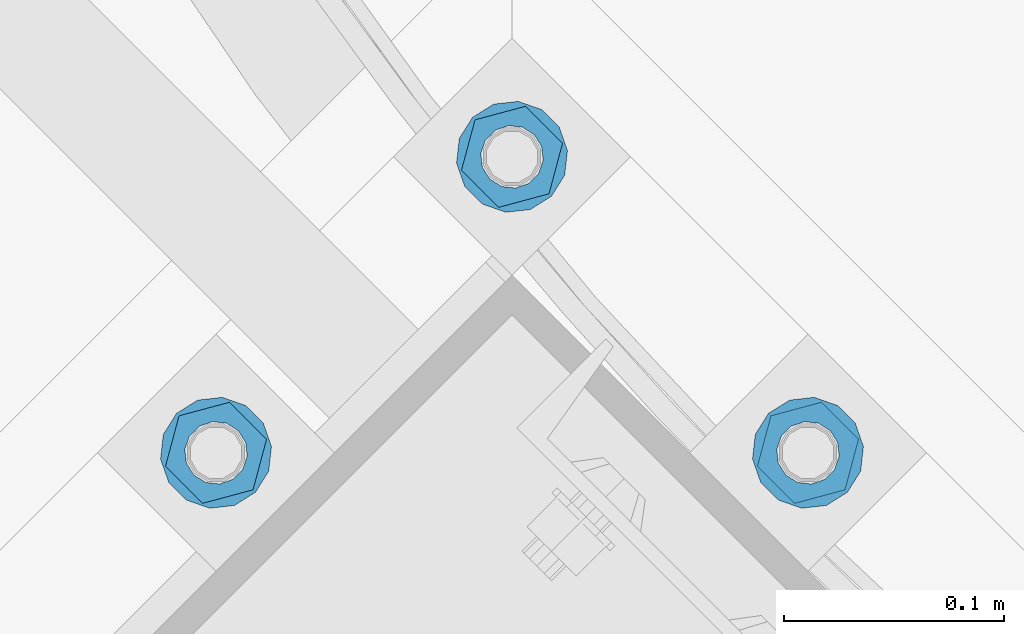
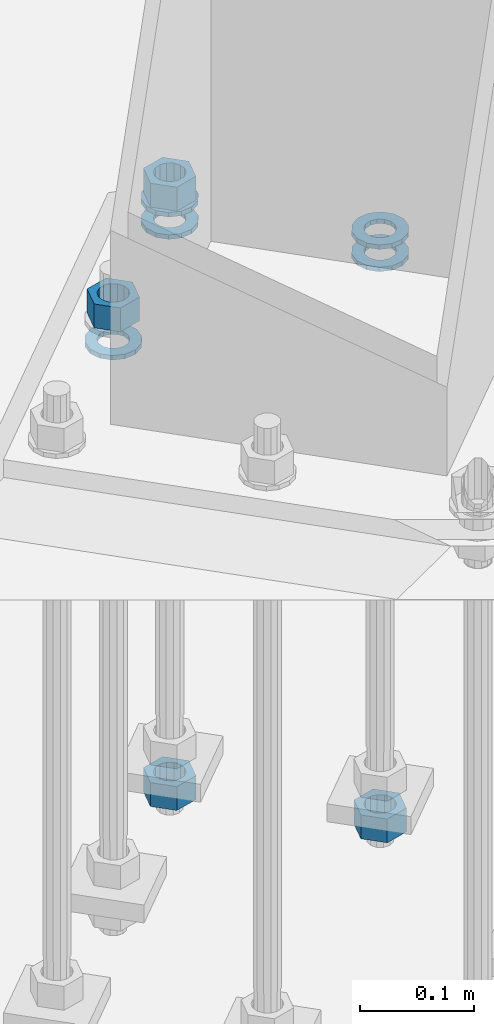
# One storey, part 864 of 1876: 9 columns, 1 element without a shape of its own.
"""IFC2X3 building model written with IfcOpenShell, lengths in millimetres."""

from ifc_helpers import new_model, si_unit, frame, origin_with_axes, place, context, subcontext, project, spatial, faceted_brep, material, type_object, element, aggregate, save


model = new_model("IFC2X3")

# Units and contexts
model_context = context("Model", 3, precision=1e-05, world=origin_with_axes())
body_context = subcontext(model_context, "Body", "Model", "MODEL_VIEW")
ifc_project = project(units=[si_unit("LENGTHUNIT", "METRE", prefix="MILLI"), si_unit("AREAUNIT", "SQUARE_METRE"), si_unit("VOLUMEUNIT", "CUBIC_METRE"), si_unit("MASSUNIT", "GRAM", prefix="KILO"), si_unit("TIMEUNIT", "SECOND"), si_unit("PLANEANGLEUNIT", "RADIAN"), si_unit("SOLIDANGLEUNIT", "STERADIAN"), si_unit("THERMODYNAMICTEMPERATUREUNIT", "DEGREE_CELSIUS"), si_unit("LUMINOUSINTENSITYUNIT", "LUMEN")], contexts=[model_context])

# Site, building, storey
site_placement = place(None, origin_with_axes())
site = spatial("IfcSite", under=ifc_project, at=site_placement, CompositionType="ELEMENT")
building_placement = place(site_placement, origin_with_axes())
building = spatial("IfcBuilding", under=site, at=building_placement, Name="Undefined", CompositionType="ELEMENT")
storey_placement = place(building_placement, origin_with_axes())
storey = spatial("IfcBuildingStorey", under=building, at=storey_placement, Name="Undefined", CompositionType="ELEMENT", Elevation=0.0)

# Assembly, columns
assembly_placement = place(storey_placement, origin_with_axes())
assembly = element("IfcElementAssembly", 1, at=assembly_placement, inside=storey, Name="TEMPLATE", AssemblyPlace="NOTDEFINED", PredefinedType="RIGID_FRAME")
ifc_material_1 = material(Name="STEEL/A563")
column_type_1 = type_object("IfcColumnType", Name="1_HEAVY_HEX_NUT", PredefinedType="NOTDEFINED")
column_1_placement = place(assembly_placement, frame((3917.62601588852, -14852.973984112, -552.45), z_axis=(0.707106781186548, 0.707106781186547, 0.0), x_axis=(0.0, 0.0, -1.0)))
column_1 = element("IfcColumn", 2, at=column_1_placement, type_object=column_type_1, material=ifc_material_1, Name="NUT", ObjectType="1_HEAVY_HEX_NUT", context=body_context, shape_type="Brep", body=[
    faceted_brep([(0.0, -23.8099994659442, 9.09494701772928e-13), (0.0, -11.9099998474121, -20.6200008392352), (25.4, -11.9099998474157, -20.6200008392361), (25.4, -23.8099994659478, 0.0), (0.0, 11.9099998474157, -20.620000839237), (25.4, 11.9099998474121, -20.620000839237), (0.0, 23.8099994659478, 9.09494701772928e-13), (25.4, 23.8099994659442, 0.0), (0.0, 11.9099998474157, 20.620000839237), (25.4, 11.9099998474121, 20.620000839237), (0.0, -11.9099998474121, 20.6200008392389), (25.4, -11.9099998474157, 20.6200008392379), (0.0, 1.81898940354586e-12, 14.2899999618567), (0.0, 6.20019861543915, 12.8748450879584), (25.4, 6.20019861543733, 12.8748450879593), (25.4, 0.0, 14.2899999618558), (0.0, 11.1723718546473, 8.90966924477925), (25.4, 11.1723718546436, 8.90966924477925), (0.0, 13.9317198278914, 3.17982413774916), (25.4, 13.9317198278877, 3.17982413775007), (0.0, 13.9317198278914, -3.17982413774644), (25.4, 13.9317198278895, -3.17982413774735), (0.0, 11.1723718546473, -8.90966924477834), (25.4, 11.1723718546455, -8.90966924477925), (0.0, 6.20019861544279, -12.8748450879575), (25.4, 6.20019861543915, -12.8748450879584), (0.0, 3.63797880709171e-12, -14.2899999618548), (25.4, -3.63797880709171e-12, -14.2899999618548), (0.0, -6.20019861543733, -12.8748450879566), (25.4, -6.20019861544097, -12.8748450879584), (0.0, -11.1723718546455, -8.90966924477743), (25.4, -11.1723718546473, -8.90966924477834), (0.0, -13.9317198278877, -3.17982413774735), (25.4, -13.9317198278914, -3.17982413774826), (0.0, -13.9317198278895, 3.17982413774735), (25.4, -13.9317198278914, 3.17982413774826), (0.0, -11.1723718546455, 8.90966924477925), (25.4, -11.1723718546473, 8.90966924478016), (0.0, -6.20019861543915, 12.8748450879593), (25.4, -6.20019861544279, 12.8748450879593)], [[[0, 1, 2, 3]], [[1, 4, 5, 2]], [[4, 6, 7, 5]], [[6, 8, 9, 7]], [[8, 10, 11, 9]], [[10, 0, 3, 11]], [[12, 13, 14, 15]], [[13, 16, 17, 14]], [[16, 18, 19, 17]], [[18, 20, 21, 19]], [[20, 22, 23, 21]], [[22, 24, 25, 23]], [[24, 26, 27, 25]], [[26, 28, 29, 27]], [[28, 30, 31, 29]], [[30, 32, 33, 31]], [[32, 34, 35, 33]], [[34, 36, 37, 35]], [[36, 38, 39, 37]], [[38, 12, 15, 39]], [[5, 7, 9, 11, 3, 2], [17, 19, 21, 23, 25, 27, 29, 31, 33, 35, 37, 39, 15, 14]], [[10, 8, 6, 4, 1, 0], [38, 36, 34, 32, 30, 28, 26, 24, 22, 20, 18, 16, 13, 12]]]),
])
column_2_placement = place(assembly_placement, frame((3782.92217407241, -14718.2701422957, 87.3125), z_axis=(-0.707106781186547, -0.707106781186548, 0.0), x_axis=(0.0, 0.0, -1.0)))
column_2 = element("IfcColumn", 3, at=column_2_placement, type_object=column_type_1, material=ifc_material_1, Name="NUT", ObjectType="1_HEAVY_HEX_NUT", context=body_context, shape_type="Brep", body=[
    faceted_brep([(0.0, -23.8099994659442, 9.09494701772928e-13), (0.0, -11.9099998474121, -20.6200008392352), (25.4, -11.9099998474157, -20.6200008392361), (25.4, -23.8099994659478, 0.0), (0.0, 11.9099998474157, -20.620000839237), (25.4, 11.9099998474121, -20.620000839237), (0.0, 23.8099994659478, 9.09494701772928e-13), (25.4, 23.8099994659442, 0.0), (0.0, 11.9099998474157, 20.620000839237), (25.4, 11.9099998474121, 20.620000839237), (0.0, -11.9099998474121, 20.6200008392389), (25.4, -11.9099998474157, 20.6200008392379), (0.0, 1.81898940354586e-12, 14.2899999618567), (0.0, 6.20019861543915, 12.8748450879584), (25.4, 6.20019861543733, 12.8748450879593), (25.4, 0.0, 14.2899999618558), (0.0, 11.1723718546473, 8.90966924477925), (25.4, 11.1723718546436, 8.90966924477925), (0.0, 13.9317198278914, 3.17982413774916), (25.4, 13.9317198278877, 3.17982413775007), (0.0, 13.9317198278914, -3.17982413774644), (25.4, 13.9317198278895, -3.17982413774735), (0.0, 11.1723718546473, -8.90966924477834), (25.4, 11.1723718546455, -8.90966924477925), (0.0, 6.20019861544279, -12.8748450879575), (25.4, 6.20019861543915, -12.8748450879584), (0.0, 3.63797880709171e-12, -14.2899999618548), (25.4, -3.63797880709171e-12, -14.2899999618548), (0.0, -6.20019861543733, -12.8748450879566), (25.4, -6.20019861544097, -12.8748450879584), (0.0, -11.1723718546455, -8.90966924477743), (25.4, -11.1723718546473, -8.90966924477834), (0.0, -13.9317198278877, -3.17982413774735), (25.4, -13.9317198278914, -3.17982413774826), (0.0, -13.9317198278895, 3.17982413774735), (25.4, -13.9317198278914, 3.17982413774826), (0.0, -11.1723718546455, 8.90966924477925), (25.4, -11.1723718546473, 8.90966924478016), (0.0, -6.20019861543915, 12.8748450879593), (25.4, -6.20019861544279, 12.8748450879593)], [[[0, 1, 2, 3]], [[1, 4, 5, 2]], [[4, 6, 7, 5]], [[6, 8, 9, 7]], [[8, 10, 11, 9]], [[10, 0, 3, 11]], [[12, 13, 14, 15]], [[13, 16, 17, 14]], [[16, 18, 19, 17]], [[18, 20, 21, 19]], [[20, 22, 23, 21]], [[22, 24, 25, 23]], [[24, 26, 27, 25]], [[26, 28, 29, 27]], [[28, 30, 31, 29]], [[30, 32, 33, 31]], [[32, 34, 35, 33]], [[34, 36, 37, 35]], [[36, 38, 39, 37]], [[38, 12, 15, 39]], [[5, 7, 9, 11, 3, 2], [17, 19, 21, 23, 25, 27, 29, 31, 33, 35, 37, 39, 15, 14]], [[10, 8, 6, 4, 1, 0], [38, 36, 34, 32, 30, 28, 26, 24, 22, 20, 18, 16, 13, 12]]]),
])
column_3_placement = place(assembly_placement, frame((3782.92217407237, -14718.2701422959, -552.45), z_axis=(-0.707106781186547, -0.707106781186548, 0.0), x_axis=(0.0, 0.0, -1.0)))
column_3 = element("IfcColumn", 4, at=column_3_placement, type_object=column_type_1, material=ifc_material_1, Name="NUT", ObjectType="1_HEAVY_HEX_NUT", context=body_context, shape_type="Brep", body=[
    faceted_brep([(0.0, -23.8099994659442, 9.09494701772928e-13), (0.0, -11.9099998474121, -20.6200008392352), (25.4, -11.9099998474157, -20.6200008392361), (25.4, -23.8099994659478, 0.0), (0.0, 11.9099998474157, -20.620000839237), (25.4, 11.9099998474121, -20.620000839237), (0.0, 23.8099994659478, 9.09494701772928e-13), (25.4, 23.8099994659442, 0.0), (0.0, 11.9099998474157, 20.620000839237), (25.4, 11.9099998474121, 20.620000839237), (0.0, -11.9099998474121, 20.6200008392389), (25.4, -11.9099998474157, 20.6200008392379), (0.0, 1.81898940354586e-12, 14.2899999618567), (0.0, 6.20019861543915, 12.8748450879584), (25.4, 6.20019861543733, 12.8748450879593), (25.4, 0.0, 14.2899999618558), (0.0, 11.1723718546473, 8.90966924477925), (25.4, 11.1723718546436, 8.90966924477925), (0.0, 13.9317198278914, 3.17982413774916), (25.4, 13.9317198278877, 3.17982413775007), (0.0, 13.9317198278914, -3.17982413774644), (25.4, 13.9317198278895, -3.17982413774735), (0.0, 11.1723718546473, -8.90966924477834), (25.4, 11.1723718546455, -8.90966924477925), (0.0, 6.20019861544279, -12.8748450879575), (25.4, 6.20019861543915, -12.8748450879584), (0.0, 3.63797880709171e-12, -14.2899999618548), (25.4, -3.63797880709171e-12, -14.2899999618548), (0.0, -6.20019861543733, -12.8748450879566), (25.4, -6.20019861544097, -12.8748450879584), (0.0, -11.1723718546455, -8.90966924477743), (25.4, -11.1723718546473, -8.90966924477834), (0.0, -13.9317198278877, -3.17982413774735), (25.4, -13.9317198278914, -3.17982413774826), (0.0, -13.9317198278895, 3.17982413774735), (25.4, -13.9317198278914, 3.17982413774826), (0.0, -11.1723718546455, 8.90966924477925), (25.4, -11.1723718546473, 8.90966924478016), (0.0, -6.20019861543915, 12.8748450879593), (25.4, -6.20019861544279, 12.8748450879593)], [[[0, 1, 2, 3]], [[1, 4, 5, 2]], [[4, 6, 7, 5]], [[6, 8, 9, 7]], [[8, 10, 11, 9]], [[10, 0, 3, 11]], [[12, 13, 14, 15]], [[13, 16, 17, 14]], [[16, 18, 19, 17]], [[18, 20, 21, 19]], [[20, 22, 23, 21]], [[22, 24, 25, 23]], [[24, 26, 27, 25]], [[26, 28, 29, 27]], [[28, 30, 31, 29]], [[30, 32, 33, 31]], [[32, 34, 35, 33]], [[34, 36, 37, 35]], [[36, 38, 39, 37]], [[38, 12, 15, 39]], [[5, 7, 9, 11, 3, 2], [17, 19, 21, 23, 25, 27, 29, 31, 33, 35, 37, 39, 15, 14]], [[10, 8, 6, 4, 1, 0], [38, 36, 34, 32, 30, 28, 26, 24, 22, 20, 18, 16, 13, 12]]]),
])
column_4_placement = place(assembly_placement, frame((3648.21833225621, -14852.9739841119, 87.3125), z_axis=(-0.707106781186547, -0.707106781186548, 0.0), x_axis=(0.0, 0.0, -1.0)))
column_4 = element("IfcColumn", 5, at=column_4_placement, type_object=column_type_1, material=ifc_material_1, Name="NUT", ObjectType="1_HEAVY_HEX_NUT", context=body_context, shape_type="Brep", body=[
    faceted_brep([(0.0, -23.8099994659442, 9.09494701772928e-13), (0.0, -11.9099998474121, -20.6200008392352), (25.4, -11.9099998474157, -20.6200008392361), (25.4, -23.8099994659478, 0.0), (0.0, 11.9099998474157, -20.620000839237), (25.4, 11.9099998474121, -20.620000839237), (0.0, 23.8099994659478, 9.09494701772928e-13), (25.4, 23.8099994659442, 0.0), (0.0, 11.9099998474157, 20.620000839237), (25.4, 11.9099998474121, 20.620000839237), (0.0, -11.9099998474121, 20.6200008392389), (25.4, -11.9099998474157, 20.6200008392379), (0.0, 1.81898940354586e-12, 14.2899999618567), (0.0, 6.20019861543915, 12.8748450879584), (25.4, 6.20019861543733, 12.8748450879593), (25.4, 0.0, 14.2899999618558), (0.0, 11.1723718546473, 8.90966924477925), (25.4, 11.1723718546436, 8.90966924477925), (0.0, 13.9317198278914, 3.17982413774916), (25.4, 13.9317198278877, 3.17982413775007), (0.0, 13.9317198278914, -3.17982413774644), (25.4, 13.9317198278895, -3.17982413774735), (0.0, 11.1723718546473, -8.90966924477834), (25.4, 11.1723718546455, -8.90966924477925), (0.0, 6.20019861544279, -12.8748450879575), (25.4, 6.20019861543915, -12.8748450879584), (0.0, 3.63797880709171e-12, -14.2899999618548), (25.4, -3.63797880709171e-12, -14.2899999618548), (0.0, -6.20019861543733, -12.8748450879566), (25.4, -6.20019861544097, -12.8748450879584), (0.0, -11.1723718546455, -8.90966924477743), (25.4, -11.1723718546473, -8.90966924477834), (0.0, -13.9317198278877, -3.17982413774735), (25.4, -13.9317198278914, -3.17982413774826), (0.0, -13.9317198278895, 3.17982413774735), (25.4, -13.9317198278914, 3.17982413774826), (0.0, -11.1723718546455, 8.90966924477925), (25.4, -11.1723718546473, 8.90966924478016), (0.0, -6.20019861543915, 12.8748450879593), (25.4, -6.20019861544279, 12.8748450879593)], [[[0, 1, 2, 3]], [[1, 4, 5, 2]], [[4, 6, 7, 5]], [[6, 8, 9, 7]], [[8, 10, 11, 9]], [[10, 0, 3, 11]], [[12, 13, 14, 15]], [[13, 16, 17, 14]], [[16, 18, 19, 17]], [[18, 20, 21, 19]], [[20, 22, 23, 21]], [[22, 24, 25, 23]], [[24, 26, 27, 25]], [[26, 28, 29, 27]], [[28, 30, 31, 29]], [[30, 32, 33, 31]], [[32, 34, 35, 33]], [[34, 36, 37, 35]], [[36, 38, 39, 37]], [[38, 12, 15, 39]], [[5, 7, 9, 11, 3, 2], [17, 19, 21, 23, 25, 27, 29, 31, 33, 35, 37, 39, 15, 14]], [[10, 8, 6, 4, 1, 0], [38, 36, 34, 32, 30, 28, 26, 24, 22, 20, 18, 16, 13, 12]]]),
])
ifc_material_2 = material(Name="STEEL/F436")
column_type_2 = type_object("IfcColumnType", Name="1_WASHER", PredefinedType="NOTDEFINED")
column_5_placement = place(assembly_placement, frame((3917.62601588861, -14852.9739841118, 38.1), z_axis=(0.707106781186548, 0.707106781186547, 0.0), x_axis=(0.0, 0.0, -1.0)))
column_5 = element("IfcColumn", 6, at=column_5_placement, type_object=column_type_2, material=ifc_material_2, Name="WASHER", ObjectType="1_WASHER", context=body_context, shape_type="Brep", body=[
    faceted_brep([(0.0, -25.3999996185375, 0.0), (0.0, -22.8846089010331, -11.0206468080742), (4.7625, -22.8846089010331, -11.0206468080742), (4.7625, -25.3999996185375, 0.0), (0.0, -15.8366407293743, -19.8585193564477), (4.7625, -15.8366407293743, -19.8585193564477), (0.0, -5.65203163760816, -24.7631685975166), (4.7625, -5.65203163760816, -24.7631685975166), (0.0, 5.65203163760452, -24.7631685975166), (4.7625, 5.65203163760452, -24.7631685975166), (0.0, 15.8366407293706, -19.858519356445), (4.7625, 15.8366407293706, -19.858519356445), (0.0, 22.8846089010331, -11.0206468080733), (4.7625, 22.8846089010331, -11.0206468080733), (0.0, 25.3999996185339, 9.09494701772928e-13), (4.7625, 25.3999996185339, 9.09494701772928e-13), (0.0, 22.8846089010331, 11.0206468080751), (4.7625, 22.8846089010331, 11.0206468080751), (0.0, 15.8366407293706, 19.8585193564486), (4.7625, 15.8366407293706, 19.8585193564486), (0.0, 5.65203163760452, 24.7631685975175), (4.7625, 5.65203163760452, 24.7631685975175), (0.0, -5.65203163760816, 24.7631685975175), (4.7625, -5.65203163760816, 24.7631685975175), (0.0, -15.8366407293724, 19.8585193564459), (4.7625, -15.8366407293724, 19.8585193564459), (0.0, -22.8846089010367, 11.0206468080751), (4.7625, -22.8846089010367, 11.0206468080751), (0.0, 1.81898940354586e-12, 14.2899999618567), (0.0, 6.20019861543915, 12.8748450879584), (4.7625, 6.20019861543733, 12.8748450879593), (4.7625, 0.0, 14.2899999618558), (0.0, 11.1723718546473, 8.90966924477925), (4.7625, 11.1723718546436, 8.90966924477925), (0.0, 13.9317198278914, 3.17982413774916), (4.7625, 13.9317198278877, 3.17982413775007), (0.0, 13.9317198278914, -3.17982413774644), (4.7625, 13.9317198278895, -3.17982413774735), (0.0, 11.1723718546473, -8.90966924477834), (4.7625, 11.1723718546455, -8.90966924477925), (0.0, 6.20019861544279, -12.8748450879575), (4.7625, 6.20019861543915, -12.8748450879584), (0.0, 3.63797880709171e-12, -14.2899999618548), (4.7625, -3.63797880709171e-12, -14.2899999618548), (0.0, -6.20019861543733, -12.8748450879566), (4.7625, -6.20019861544097, -12.8748450879584), (0.0, -11.1723718546455, -8.90966924477743), (4.7625, -11.1723718546473, -8.90966924477834), (0.0, -13.9317198278877, -3.17982413774735), (4.7625, -13.9317198278914, -3.17982413774826), (0.0, -13.9317198278895, 3.17982413774735), (4.7625, -13.9317198278914, 3.17982413774826), (0.0, -11.1723718546455, 8.90966924477925), (4.7625, -11.1723718546473, 8.90966924478016), (0.0, -6.20019861543915, 12.8748450879593), (4.7625, -6.20019861544279, 12.8748450879593)], [[[0, 1, 2, 3]], [[1, 4, 5, 2]], [[4, 6, 7, 5]], [[6, 8, 9, 7]], [[8, 10, 11, 9]], [[10, 12, 13, 11]], [[12, 14, 15, 13]], [[14, 16, 17, 15]], [[16, 18, 19, 17]], [[18, 20, 21, 19]], [[20, 22, 23, 21]], [[22, 24, 25, 23]], [[24, 26, 27, 25]], [[26, 0, 3, 27]], [[28, 29, 30, 31]], [[29, 32, 33, 30]], [[32, 34, 35, 33]], [[34, 36, 37, 35]], [[36, 38, 39, 37]], [[38, 40, 41, 39]], [[40, 42, 43, 41]], [[42, 44, 45, 43]], [[44, 46, 47, 45]], [[46, 48, 49, 47]], [[48, 50, 51, 49]], [[50, 52, 53, 51]], [[52, 54, 55, 53]], [[54, 28, 31, 55]], [[5, 7, 9, 11, 13, 15, 17, 19, 21, 23, 25, 27, 3, 2], [33, 35, 37, 39, 41, 43, 45, 47, 49, 51, 53, 55, 31, 30]], [[26, 24, 22, 20, 18, 16, 14, 12, 10, 8, 6, 4, 1, 0], [54, 52, 50, 48, 46, 44, 42, 40, 38, 36, 34, 32, 29, 28]]]),
])
column_6_placement = place(assembly_placement, frame((3917.6260158887, -14852.9739841117, 61.9125), z_axis=(0.707106781186548, 0.707106781186547, 0.0), x_axis=(0.0, 0.0, -1.0)))
column_6 = element("IfcColumn", 7, at=column_6_placement, type_object=column_type_2, material=ifc_material_2, Name="WASHER", ObjectType="1_WASHER", context=body_context, shape_type="Brep", body=[
    faceted_brep([(0.0, -25.3999996185375, 0.0), (0.0, -22.8846089010331, -11.0206468080742), (4.7625, -22.8846089010331, -11.0206468080742), (4.7625, -25.3999996185375, 0.0), (0.0, -15.8366407293743, -19.8585193564477), (4.7625, -15.8366407293743, -19.8585193564477), (0.0, -5.65203163760816, -24.7631685975166), (4.7625, -5.65203163760816, -24.7631685975166), (0.0, 5.65203163760452, -24.7631685975166), (4.7625, 5.65203163760452, -24.7631685975166), (0.0, 15.8366407293706, -19.858519356445), (4.7625, 15.8366407293706, -19.858519356445), (0.0, 22.8846089010331, -11.0206468080733), (4.7625, 22.8846089010331, -11.0206468080733), (0.0, 25.3999996185339, 9.09494701772928e-13), (4.7625, 25.3999996185339, 9.09494701772928e-13), (0.0, 22.8846089010331, 11.0206468080751), (4.7625, 22.8846089010331, 11.0206468080751), (0.0, 15.8366407293706, 19.8585193564486), (4.7625, 15.8366407293706, 19.8585193564486), (0.0, 5.65203163760452, 24.7631685975175), (4.7625, 5.65203163760452, 24.7631685975175), (0.0, -5.65203163760816, 24.7631685975175), (4.7625, -5.65203163760816, 24.7631685975175), (0.0, -15.8366407293724, 19.8585193564459), (4.7625, -15.8366407293724, 19.8585193564459), (0.0, -22.8846089010367, 11.0206468080751), (4.7625, -22.8846089010367, 11.0206468080751), (0.0, 1.81898940354586e-12, 14.2899999618567), (0.0, 6.20019861543915, 12.8748450879584), (4.7625, 6.20019861543733, 12.8748450879593), (4.7625, 0.0, 14.2899999618558), (0.0, 11.1723718546473, 8.90966924477925), (4.7625, 11.1723718546436, 8.90966924477925), (0.0, 13.9317198278914, 3.17982413774916), (4.7625, 13.9317198278877, 3.17982413775007), (0.0, 13.9317198278914, -3.17982413774644), (4.7625, 13.9317198278895, -3.17982413774735), (0.0, 11.1723718546473, -8.90966924477834), (4.7625, 11.1723718546455, -8.90966924477925), (0.0, 6.20019861544279, -12.8748450879575), (4.7625, 6.20019861543915, -12.8748450879584), (0.0, 3.63797880709171e-12, -14.2899999618548), (4.7625, -3.63797880709171e-12, -14.2899999618548), (0.0, -6.20019861543733, -12.8748450879566), (4.7625, -6.20019861544097, -12.8748450879584), (0.0, -11.1723718546455, -8.90966924477743), (4.7625, -11.1723718546473, -8.90966924477834), (0.0, -13.9317198278877, -3.17982413774735), (4.7625, -13.9317198278914, -3.17982413774826), (0.0, -13.9317198278895, 3.17982413774735), (4.7625, -13.9317198278914, 3.17982413774826), (0.0, -11.1723718546455, 8.90966924477925), (4.7625, -11.1723718546473, 8.90966924478016), (0.0, -6.20019861543915, 12.8748450879593), (4.7625, -6.20019861544279, 12.8748450879593)], [[[0, 1, 2, 3]], [[1, 4, 5, 2]], [[4, 6, 7, 5]], [[6, 8, 9, 7]], [[8, 10, 11, 9]], [[10, 12, 13, 11]], [[12, 14, 15, 13]], [[14, 16, 17, 15]], [[16, 18, 19, 17]], [[18, 20, 21, 19]], [[20, 22, 23, 21]], [[22, 24, 25, 23]], [[24, 26, 27, 25]], [[26, 0, 3, 27]], [[28, 29, 30, 31]], [[29, 32, 33, 30]], [[32, 34, 35, 33]], [[34, 36, 37, 35]], [[36, 38, 39, 37]], [[38, 40, 41, 39]], [[40, 42, 43, 41]], [[42, 44, 45, 43]], [[44, 46, 47, 45]], [[46, 48, 49, 47]], [[48, 50, 51, 49]], [[50, 52, 53, 51]], [[52, 54, 55, 53]], [[54, 28, 31, 55]], [[5, 7, 9, 11, 13, 15, 17, 19, 21, 23, 25, 27, 3, 2], [33, 35, 37, 39, 41, 43, 45, 47, 49, 51, 53, 55, 31, 30]], [[26, 24, 22, 20, 18, 16, 14, 12, 10, 8, 6, 4, 1, 0], [54, 52, 50, 48, 46, 44, 42, 40, 38, 36, 34, 32, 29, 28]]]),
])
column_7_placement = place(assembly_placement, frame((3782.92217407241, -14718.2701422956, 38.1), z_axis=(-0.707106781186547, -0.707106781186548, 0.0), x_axis=(0.0, 0.0, -1.0)))
column_7 = element("IfcColumn", 8, at=column_7_placement, type_object=column_type_2, material=ifc_material_2, Name="WASHER", ObjectType="1_WASHER", context=body_context, shape_type="Brep", body=[
    faceted_brep([(0.0, -25.3999996185375, 0.0), (0.0, -22.8846089010331, -11.0206468080742), (4.7625, -22.8846089010331, -11.0206468080742), (4.7625, -25.3999996185375, 0.0), (0.0, -15.8366407293743, -19.8585193564477), (4.7625, -15.8366407293743, -19.8585193564477), (0.0, -5.65203163760816, -24.7631685975166), (4.7625, -5.65203163760816, -24.7631685975166), (0.0, 5.65203163760452, -24.7631685975166), (4.7625, 5.65203163760452, -24.7631685975166), (0.0, 15.8366407293706, -19.858519356445), (4.7625, 15.8366407293706, -19.858519356445), (0.0, 22.8846089010331, -11.0206468080733), (4.7625, 22.8846089010331, -11.0206468080733), (0.0, 25.3999996185339, 9.09494701772928e-13), (4.7625, 25.3999996185339, 9.09494701772928e-13), (0.0, 22.8846089010331, 11.0206468080751), (4.7625, 22.8846089010331, 11.0206468080751), (0.0, 15.8366407293706, 19.8585193564486), (4.7625, 15.8366407293706, 19.8585193564486), (0.0, 5.65203163760452, 24.7631685975175), (4.7625, 5.65203163760452, 24.7631685975175), (0.0, -5.65203163760816, 24.7631685975175), (4.7625, -5.65203163760816, 24.7631685975175), (0.0, -15.8366407293724, 19.8585193564459), (4.7625, -15.8366407293724, 19.8585193564459), (0.0, -22.8846089010367, 11.0206468080751), (4.7625, -22.8846089010367, 11.0206468080751), (0.0, 1.81898940354586e-12, 14.2899999618567), (0.0, 6.20019861543915, 12.8748450879584), (4.7625, 6.20019861543733, 12.8748450879593), (4.7625, 0.0, 14.2899999618558), (0.0, 11.1723718546473, 8.90966924477925), (4.7625, 11.1723718546436, 8.90966924477925), (0.0, 13.9317198278914, 3.17982413774916), (4.7625, 13.9317198278877, 3.17982413775007), (0.0, 13.9317198278914, -3.17982413774644), (4.7625, 13.9317198278895, -3.17982413774735), (0.0, 11.1723718546473, -8.90966924477834), (4.7625, 11.1723718546455, -8.90966924477925), (0.0, 6.20019861544279, -12.8748450879575), (4.7625, 6.20019861543915, -12.8748450879584), (0.0, 3.63797880709171e-12, -14.2899999618548), (4.7625, -3.63797880709171e-12, -14.2899999618548), (0.0, -6.20019861543733, -12.8748450879566), (4.7625, -6.20019861544097, -12.8748450879584), (0.0, -11.1723718546455, -8.90966924477743), (4.7625, -11.1723718546473, -8.90966924477834), (0.0, -13.9317198278877, -3.17982413774735), (4.7625, -13.9317198278914, -3.17982413774826), (0.0, -13.9317198278895, 3.17982413774735), (4.7625, -13.9317198278914, 3.17982413774826), (0.0, -11.1723718546455, 8.90966924477925), (4.7625, -11.1723718546473, 8.90966924478016), (0.0, -6.20019861543915, 12.8748450879593), (4.7625, -6.20019861544279, 12.8748450879593)], [[[0, 1, 2, 3]], [[1, 4, 5, 2]], [[4, 6, 7, 5]], [[6, 8, 9, 7]], [[8, 10, 11, 9]], [[10, 12, 13, 11]], [[12, 14, 15, 13]], [[14, 16, 17, 15]], [[16, 18, 19, 17]], [[18, 20, 21, 19]], [[20, 22, 23, 21]], [[22, 24, 25, 23]], [[24, 26, 27, 25]], [[26, 0, 3, 27]], [[28, 29, 30, 31]], [[29, 32, 33, 30]], [[32, 34, 35, 33]], [[34, 36, 37, 35]], [[36, 38, 39, 37]], [[38, 40, 41, 39]], [[40, 42, 43, 41]], [[42, 44, 45, 43]], [[44, 46, 47, 45]], [[46, 48, 49, 47]], [[48, 50, 51, 49]], [[50, 52, 53, 51]], [[52, 54, 55, 53]], [[54, 28, 31, 55]], [[5, 7, 9, 11, 13, 15, 17, 19, 21, 23, 25, 27, 3, 2], [33, 35, 37, 39, 41, 43, 45, 47, 49, 51, 53, 55, 31, 30]], [[26, 24, 22, 20, 18, 16, 14, 12, 10, 8, 6, 4, 1, 0], [54, 52, 50, 48, 46, 44, 42, 40, 38, 36, 34, 32, 29, 28]]]),
])
column_8_placement = place(assembly_placement, frame((3782.92217407246, -14718.2701422955, 61.9125), z_axis=(-0.707106781186547, -0.707106781186548, 0.0), x_axis=(0.0, 0.0, -1.0)))
column_8 = element("IfcColumn", 9, at=column_8_placement, type_object=column_type_2, material=ifc_material_2, Name="WASHER", ObjectType="1_WASHER", context=body_context, shape_type="Brep", body=[
    faceted_brep([(0.0, -25.3999996185375, 0.0), (0.0, -22.8846089010331, -11.0206468080742), (4.7625, -22.8846089010331, -11.0206468080742), (4.7625, -25.3999996185375, 0.0), (0.0, -15.8366407293743, -19.8585193564477), (4.7625, -15.8366407293743, -19.8585193564477), (0.0, -5.65203163760816, -24.7631685975166), (4.7625, -5.65203163760816, -24.7631685975166), (0.0, 5.65203163760452, -24.7631685975166), (4.7625, 5.65203163760452, -24.7631685975166), (0.0, 15.8366407293706, -19.858519356445), (4.7625, 15.8366407293706, -19.858519356445), (0.0, 22.8846089010331, -11.0206468080733), (4.7625, 22.8846089010331, -11.0206468080733), (0.0, 25.3999996185339, 9.09494701772928e-13), (4.7625, 25.3999996185339, 9.09494701772928e-13), (0.0, 22.8846089010331, 11.0206468080751), (4.7625, 22.8846089010331, 11.0206468080751), (0.0, 15.8366407293706, 19.8585193564486), (4.7625, 15.8366407293706, 19.8585193564486), (0.0, 5.65203163760452, 24.7631685975175), (4.7625, 5.65203163760452, 24.7631685975175), (0.0, -5.65203163760816, 24.7631685975175), (4.7625, -5.65203163760816, 24.7631685975175), (0.0, -15.8366407293724, 19.8585193564459), (4.7625, -15.8366407293724, 19.8585193564459), (0.0, -22.8846089010367, 11.0206468080751), (4.7625, -22.8846089010367, 11.0206468080751), (0.0, 1.81898940354586e-12, 14.2899999618567), (0.0, 6.20019861543915, 12.8748450879584), (4.7625, 6.20019861543733, 12.8748450879593), (4.7625, 0.0, 14.2899999618558), (0.0, 11.1723718546473, 8.90966924477925), (4.7625, 11.1723718546436, 8.90966924477925), (0.0, 13.9317198278914, 3.17982413774916), (4.7625, 13.9317198278877, 3.17982413775007), (0.0, 13.9317198278914, -3.17982413774644), (4.7625, 13.9317198278895, -3.17982413774735), (0.0, 11.1723718546473, -8.90966924477834), (4.7625, 11.1723718546455, -8.90966924477925), (0.0, 6.20019861544279, -12.8748450879575), (4.7625, 6.20019861543915, -12.8748450879584), (0.0, 3.63797880709171e-12, -14.2899999618548), (4.7625, -3.63797880709171e-12, -14.2899999618548), (0.0, -6.20019861543733, -12.8748450879566), (4.7625, -6.20019861544097, -12.8748450879584), (0.0, -11.1723718546455, -8.90966924477743), (4.7625, -11.1723718546473, -8.90966924477834), (0.0, -13.9317198278877, -3.17982413774735), (4.7625, -13.9317198278914, -3.17982413774826), (0.0, -13.9317198278895, 3.17982413774735), (4.7625, -13.9317198278914, 3.17982413774826), (0.0, -11.1723718546455, 8.90966924477925), (4.7625, -11.1723718546473, 8.90966924478016), (0.0, -6.20019861543915, 12.8748450879593), (4.7625, -6.20019861544279, 12.8748450879593)], [[[0, 1, 2, 3]], [[1, 4, 5, 2]], [[4, 6, 7, 5]], [[6, 8, 9, 7]], [[8, 10, 11, 9]], [[10, 12, 13, 11]], [[12, 14, 15, 13]], [[14, 16, 17, 15]], [[16, 18, 19, 17]], [[18, 20, 21, 19]], [[20, 22, 23, 21]], [[22, 24, 25, 23]], [[24, 26, 27, 25]], [[26, 0, 3, 27]], [[28, 29, 30, 31]], [[29, 32, 33, 30]], [[32, 34, 35, 33]], [[34, 36, 37, 35]], [[36, 38, 39, 37]], [[38, 40, 41, 39]], [[40, 42, 43, 41]], [[42, 44, 45, 43]], [[44, 46, 47, 45]], [[46, 48, 49, 47]], [[48, 50, 51, 49]], [[50, 52, 53, 51]], [[52, 54, 55, 53]], [[54, 28, 31, 55]], [[5, 7, 9, 11, 13, 15, 17, 19, 21, 23, 25, 27, 3, 2], [33, 35, 37, 39, 41, 43, 45, 47, 49, 51, 53, 55, 31, 30]], [[26, 24, 22, 20, 18, 16, 14, 12, 10, 8, 6, 4, 1, 0], [54, 52, 50, 48, 46, 44, 42, 40, 38, 36, 34, 32, 29, 28]]]),
])
column_9_placement = place(assembly_placement, frame((3648.21833225621, -14852.9739841116, 38.1), z_axis=(-0.707106781186547, -0.707106781186548, 0.0), x_axis=(0.0, 0.0, -1.0)))
column_9 = element("IfcColumn", 10, at=column_9_placement, type_object=column_type_2, material=ifc_material_2, Name="WASHER", ObjectType="1_WASHER", context=body_context, shape_type="Brep", body=[
    faceted_brep([(0.0, -25.3999996185375, 0.0), (0.0, -22.8846089010331, -11.0206468080742), (4.7625, -22.8846089010331, -11.0206468080742), (4.7625, -25.3999996185375, 0.0), (0.0, -15.8366407293743, -19.8585193564477), (4.7625, -15.8366407293743, -19.8585193564477), (0.0, -5.65203163760816, -24.7631685975166), (4.7625, -5.65203163760816, -24.7631685975166), (0.0, 5.65203163760452, -24.7631685975166), (4.7625, 5.65203163760452, -24.7631685975166), (0.0, 15.8366407293706, -19.858519356445), (4.7625, 15.8366407293706, -19.858519356445), (0.0, 22.8846089010331, -11.0206468080733), (4.7625, 22.8846089010331, -11.0206468080733), (0.0, 25.3999996185339, 9.09494701772928e-13), (4.7625, 25.3999996185339, 9.09494701772928e-13), (0.0, 22.8846089010331, 11.0206468080751), (4.7625, 22.8846089010331, 11.0206468080751), (0.0, 15.8366407293706, 19.8585193564486), (4.7625, 15.8366407293706, 19.8585193564486), (0.0, 5.65203163760452, 24.7631685975175), (4.7625, 5.65203163760452, 24.7631685975175), (0.0, -5.65203163760816, 24.7631685975175), (4.7625, -5.65203163760816, 24.7631685975175), (0.0, -15.8366407293724, 19.8585193564459), (4.7625, -15.8366407293724, 19.8585193564459), (0.0, -22.8846089010367, 11.0206468080751), (4.7625, -22.8846089010367, 11.0206468080751), (0.0, 1.81898940354586e-12, 14.2899999618567), (0.0, 6.20019861543915, 12.8748450879584), (4.7625, 6.20019861543733, 12.8748450879593), (4.7625, 0.0, 14.2899999618558), (0.0, 11.1723718546473, 8.90966924477925), (4.7625, 11.1723718546436, 8.90966924477925), (0.0, 13.9317198278914, 3.17982413774916), (4.7625, 13.9317198278877, 3.17982413775007), (0.0, 13.9317198278914, -3.17982413774644), (4.7625, 13.9317198278895, -3.17982413774735), (0.0, 11.1723718546473, -8.90966924477834), (4.7625, 11.1723718546455, -8.90966924477925), (0.0, 6.20019861544279, -12.8748450879575), (4.7625, 6.20019861543915, -12.8748450879584), (0.0, 3.63797880709171e-12, -14.2899999618548), (4.7625, -3.63797880709171e-12, -14.2899999618548), (0.0, -6.20019861543733, -12.8748450879566), (4.7625, -6.20019861544097, -12.8748450879584), (0.0, -11.1723718546455, -8.90966924477743), (4.7625, -11.1723718546473, -8.90966924477834), (0.0, -13.9317198278877, -3.17982413774735), (4.7625, -13.9317198278914, -3.17982413774826), (0.0, -13.9317198278895, 3.17982413774735), (4.7625, -13.9317198278914, 3.17982413774826), (0.0, -11.1723718546455, 8.90966924477925), (4.7625, -11.1723718546473, 8.90966924478016), (0.0, -6.20019861543915, 12.8748450879593), (4.7625, -6.20019861544279, 12.8748450879593)], [[[0, 1, 2, 3]], [[1, 4, 5, 2]], [[4, 6, 7, 5]], [[6, 8, 9, 7]], [[8, 10, 11, 9]], [[10, 12, 13, 11]], [[12, 14, 15, 13]], [[14, 16, 17, 15]], [[16, 18, 19, 17]], [[18, 20, 21, 19]], [[20, 22, 23, 21]], [[22, 24, 25, 23]], [[24, 26, 27, 25]], [[26, 0, 3, 27]], [[28, 29, 30, 31]], [[29, 32, 33, 30]], [[32, 34, 35, 33]], [[34, 36, 37, 35]], [[36, 38, 39, 37]], [[38, 40, 41, 39]], [[40, 42, 43, 41]], [[42, 44, 45, 43]], [[44, 46, 47, 45]], [[46, 48, 49, 47]], [[48, 50, 51, 49]], [[50, 52, 53, 51]], [[52, 54, 55, 53]], [[54, 28, 31, 55]], [[5, 7, 9, 11, 13, 15, 17, 19, 21, 23, 25, 27, 3, 2], [33, 35, 37, 39, 41, 43, 45, 47, 49, 51, 53, 55, 31, 30]], [[26, 24, 22, 20, 18, 16, 14, 12, 10, 8, 6, 4, 1, 0], [54, 52, 50, 48, 46, 44, 42, 40, 38, 36, 34, 32, 29, 28]]]),
])
aggregate(assembly, [column_5, column_6, column_1, column_2, column_7, column_8, column_3, column_4, column_9])

save(model, "model.ifc")
